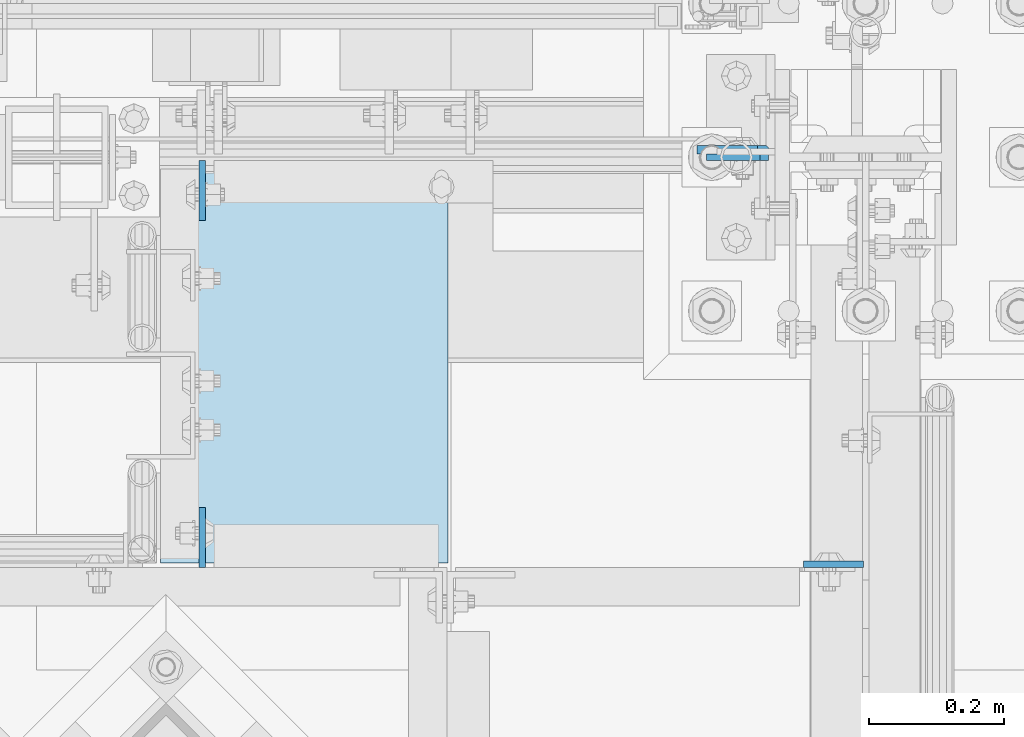
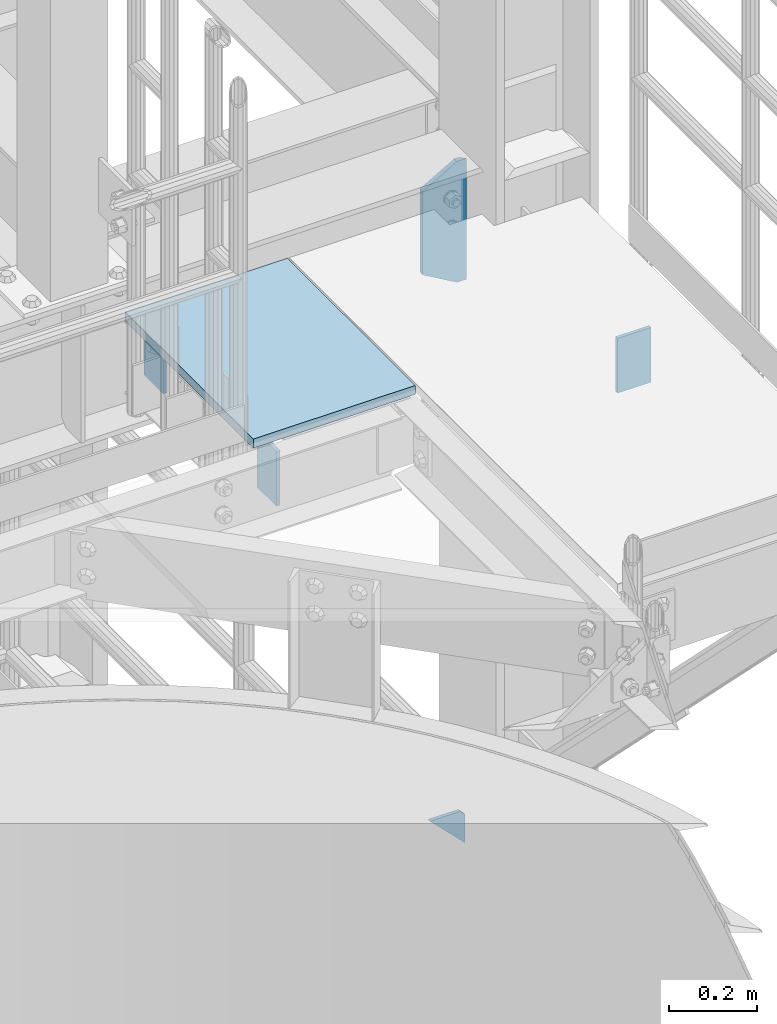
# One storey, part 1455 of 1876: 6 plates, 5 elements without a shape of their own.
"""IFC2X3 building model written with IfcOpenShell, lengths in millimetres."""

from ifc_helpers import new_model, si_unit, frame, origin_with_axes, place, context, subcontext, project, spatial, faceted_brep, material, type_object, element, aggregate, save


model = new_model("IFC2X3")

# Units and contexts
model_context = context("Model", 3, precision=1e-05, world=origin_with_axes())
body_context = subcontext(model_context, "Body", "Model", "MODEL_VIEW")
ifc_project = project(units=[si_unit("LENGTHUNIT", "METRE", prefix="MILLI"), si_unit("AREAUNIT", "SQUARE_METRE"), si_unit("VOLUMEUNIT", "CUBIC_METRE"), si_unit("MASSUNIT", "GRAM", prefix="KILO"), si_unit("TIMEUNIT", "SECOND"), si_unit("PLANEANGLEUNIT", "RADIAN"), si_unit("SOLIDANGLEUNIT", "STERADIAN"), si_unit("THERMODYNAMICTEMPERATUREUNIT", "DEGREE_CELSIUS"), si_unit("LUMINOUSINTENSITYUNIT", "LUMEN")], contexts=[model_context])

# Site, building, storey
site_placement = place(None, origin_with_axes())
site = spatial("IfcSite", under=ifc_project, at=site_placement, CompositionType="ELEMENT")
building_placement = place(site_placement, origin_with_axes())
building = spatial("IfcBuilding", under=site, at=building_placement, Name="Undefined", CompositionType="ELEMENT")
storey_placement = place(building_placement, origin_with_axes())
storey = spatial("IfcBuildingStorey", under=building, at=storey_placement, Name="Undefined", CompositionType="ELEMENT", Elevation=0.0)

# Assembly, plates
assembly_1_placement = place(storey_placement, origin_with_axes())
assembly_1 = element("IfcElementAssembly", 1, at=assembly_1_placement, inside=storey, Name="COLUMN", AssemblyPlace="NOTDEFINED", PredefinedType="RIGID_FRAME")
ifc_material_1 = material(Name="STEEL/A36")
plate_type_1 = type_object("IfcPlateType", PredefinedType="NOTDEFINED")
plate_1_placement = place(assembly_1_placement, frame((7383.44325686359, -7112.00000000001, 6311.90001063848), z_axis=(0.707106779186547, 0.0, 0.707106783186548), x_axis=(0.707106783186548, 4.99999675792934e-09, -0.707106779186547)))
plate_1 = element("IfcPlate", 2, at=plate_1_placement, type_object=plate_type_1, material=ifc_material_1, Name="PLATE", context=body_context, shape_type="Brep", body=[
    faceted_brep([(0.0, -4.76249999999982, 0.0), (56.1266013136901, -4.76249999997708, 56.1266013135391), (56.1266013136883, 4.76250000002256, 56.1266013135428), (0.0, 4.76249999999982, 0.0), (74.0871132860975, -4.7624999999698, 56.1266013135246), (74.0871132860993, 4.76250000002983, 56.1266013135282), (130.213714599717, -4.76249999994707, -1.30967237055302e-10), (130.213714599715, 4.76250000005257, -1.23691279441118e-10)], [[[0, 1, 2, 3]], [[1, 4, 5, 2]], [[4, 6, 7, 5]], [[6, 0, 3, 7]], [[5, 7, 3, 2]], [[6, 4, 1, 0]]]),
])
ifc_material_2 = material(Name="STEEL/A572-50")
plate_type_2 = type_object("IfcPlateType", PredefinedType="NOTDEFINED")
plate_2_placement = place(assembly_1_placement, frame((7485.0625, -7100.88799991608, 8116.8875), z_axis=(-1.0, 0.0, 0.0), x_axis=(0.0, 0.0, -1.0)))
plate_2 = element("IfcPlate", 3, at=plate_2_placement, type_object=plate_type_2, material=ifc_material_2, Name="PLATE", context=body_context, shape_type="Brep", body=[
    faceted_brep([(336.549987792969, 6.35000000000036, 0.0), (336.549993896485, -6.35000000000036, 12.6999999999998), (0.0, -6.35000000000036, 12.6999999999998), (0.0, 6.35000000000036, 0.0), (336.550000000001, -6.35000000000036, 25.4000000000005), (336.549987792969, 6.35000000000036, 25.4000000000005), (284.53616791736, 6.35000000000036, 115.490600585938), (284.53616791736, -6.35000000000036, 115.490600307004), (52.0138320922852, -6.35000000000036, 115.490599060059), (52.0138320922852, 6.35000000000036, 115.490600585938), (0.0, 6.35000000000036, 25.4000000000005), (0.0, -6.35000000000036, 25.4000000000005)], [[[0, 1, 2, 3]], [[4, 5, 6, 7]], [[8, 9, 10, 11]], [[11, 10, 3, 2]], [[4, 7, 8, 11, 2, 1]], [[9, 8, 7, 6]], [[0, 3, 10, 9, 6, 5]], [[5, 4, 1, 0]]]),
])
aggregate(assembly_1, [plate_1, plate_2])

# Assembly, plate
assembly_2_placement = place(storey_placement, origin_with_axes())
assembly_2 = element("IfcElementAssembly", 4, at=assembly_2_placement, inside=storey, Name="GRATING", AssemblyPlace="NOTDEFINED", PredefinedType="NOTDEFINED")
ifc_material_3 = material(Name="1")
plate_type_3 = type_object("IfcPlateType", PredefinedType="NOTDEFINED")
plate_3_placement = place(assembly_2_placement, frame((6999.28937227844, -7131.04999998984, 8010.525), z_axis=(0.0, -1.0, 0.0), x_axis=(-1.0, 0.0, 0.0)))
plate_3 = element("IfcPlate", 5, at=plate_3_placement, type_object=plate_type_3, material=ifc_material_3, Name="GRATING", context=body_context, shape_type="Brep", body=[
    faceted_brep([(0.0, -12.6999999999998, 0.0), (-4.23733581556007e-09, -12.6999999999998, 584.164367675781), (-4.23733581556007e-09, 12.6999999999998, 584.164367675781), (0.0, 12.6999999999998, 0.0), (427.039367675795, -12.6999999999998, 584.164367675772), (427.039367675795, 12.6999999999998, 584.164367675772), (427.039367675781, -12.6999999999998, -7.5488060247153e-11), (427.039367675781, 12.6999999999998, -7.5488060247153e-11)], [[[0, 1, 2, 3]], [[1, 4, 5, 2]], [[4, 6, 7, 5]], [[6, 0, 3, 7]], [[5, 7, 3, 2]], [[6, 4, 1, 0]]]),
])
aggregate(assembly_2, [plate_3])

assembly_3_placement = place(storey_placement, origin_with_axes())
assembly_3 = element("IfcElementAssembly", 6, at=assembly_3_placement, inside=storey, Name="BEAM", AssemblyPlace="NOTDEFINED", PredefinedType="RIGID_FRAME")
plate_type_4 = type_object("IfcPlateType", PredefinedType="NOTDEFINED")
plate_4_placement = place(assembly_3_placement, frame((6634.1625, -7116.7625, 7972.425), z_axis=(0.0, -1.0, 0.0), x_axis=(0.0, 0.0, -1.0)))
plate_4 = element("IfcPlate", 7, at=plate_4_placement, type_object=plate_type_4, material=ifc_material_1, Name="PLATE", context=body_context, shape_type="Brep", body=[
    faceted_brep([(0.0, -4.76249999999982, 0.0), (0.0, -4.76249999999982, 88.9000015258789), (0.0, 4.76249999999982, 88.9000015258789), (0.0, 4.76249999999982, 0.0), (152.399993896484, -4.76249999999982, 88.9000015258789), (152.399993896484, 4.76249999999982, 88.9000015258789), (152.399993896484, -4.76249999999982, 0.0), (152.399993896484, 4.76249999999982, 0.0)], [[[0, 1, 2, 3]], [[1, 4, 5, 2]], [[4, 6, 7, 5]], [[6, 0, 3, 7]], [[5, 7, 3, 2]], [[6, 4, 1, 0]]]),
])
aggregate(assembly_3, [plate_4])

assembly_4_placement = place(storey_placement, origin_with_axes())
assembly_4 = element("IfcElementAssembly", 8, at=assembly_4_placement, inside=storey, Name="BEAM", AssemblyPlace="NOTDEFINED", PredefinedType="RIGID_FRAME")
plate_5_placement = place(assembly_4_placement, frame((6634.1625, -7721.56440429563, 7972.425), z_axis=(0.0, 1.0, 0.0), x_axis=(0.0, 0.0, -1.0)))
plate_5 = element("IfcPlate", 9, at=plate_5_placement, type_object=plate_type_4, material=ifc_material_1, Name="PLATE", context=body_context, shape_type="Brep", body=[
    faceted_brep([(0.0, -4.76249999999982, 0.0), (0.0, -4.76249999999982, 88.9000015258789), (0.0, 4.76249999999982, 88.9000015258789), (0.0, 4.76249999999982, 0.0), (152.399993896484, -4.76249999999982, 88.9000015258789), (152.399993896484, 4.76249999999982, 88.9000015258789), (152.399993896484, -4.76249999999982, 0.0), (152.399993896484, 4.76249999999982, 0.0)], [[[0, 1, 2, 3]], [[1, 4, 5, 2]], [[4, 6, 7, 5]], [[6, 0, 3, 7]], [[5, 7, 3, 2]], [[6, 4, 1, 0]]]),
])
aggregate(assembly_4, [plate_5])

assembly_5_placement = place(storey_placement, origin_with_axes())
assembly_5 = element("IfcElementAssembly", 10, at=assembly_5_placement, inside=storey, Name="BEAM", AssemblyPlace="NOTDEFINED", PredefinedType="RIGID_FRAME")
plate_6_placement = place(assembly_5_placement, frame((7616.825, -7716.80190429563, 7972.425), z_axis=(-1.0, 0.0, 0.0), x_axis=(0.0, 0.0, -1.0)))
plate_6 = element("IfcPlate", 11, at=plate_6_placement, type_object=plate_type_4, material=ifc_material_1, Name="PLATE", context=body_context, shape_type="Brep", body=[
    faceted_brep([(0.0, -4.76249999999982, 0.0), (0.0, -4.76249999999982, 88.9000015258789), (0.0, 4.76249999999982, 88.9000015258789), (0.0, 4.76249999999982, 0.0), (152.399993896484, -4.76249999999982, 88.9000015258789), (152.399993896484, 4.76249999999982, 88.9000015258789), (152.399993896484, -4.76249999999982, 0.0), (152.399993896484, 4.76249999999982, 0.0)], [[[0, 1, 2, 3]], [[1, 4, 5, 2]], [[4, 6, 7, 5]], [[6, 0, 3, 7]], [[5, 7, 3, 2]], [[6, 4, 1, 0]]]),
])
aggregate(assembly_5, [plate_6])

save(model, "model.ifc")
